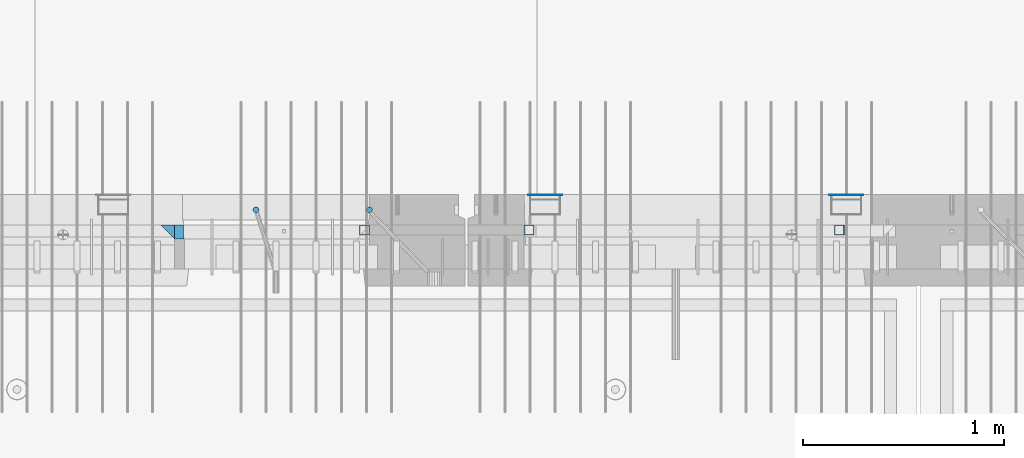
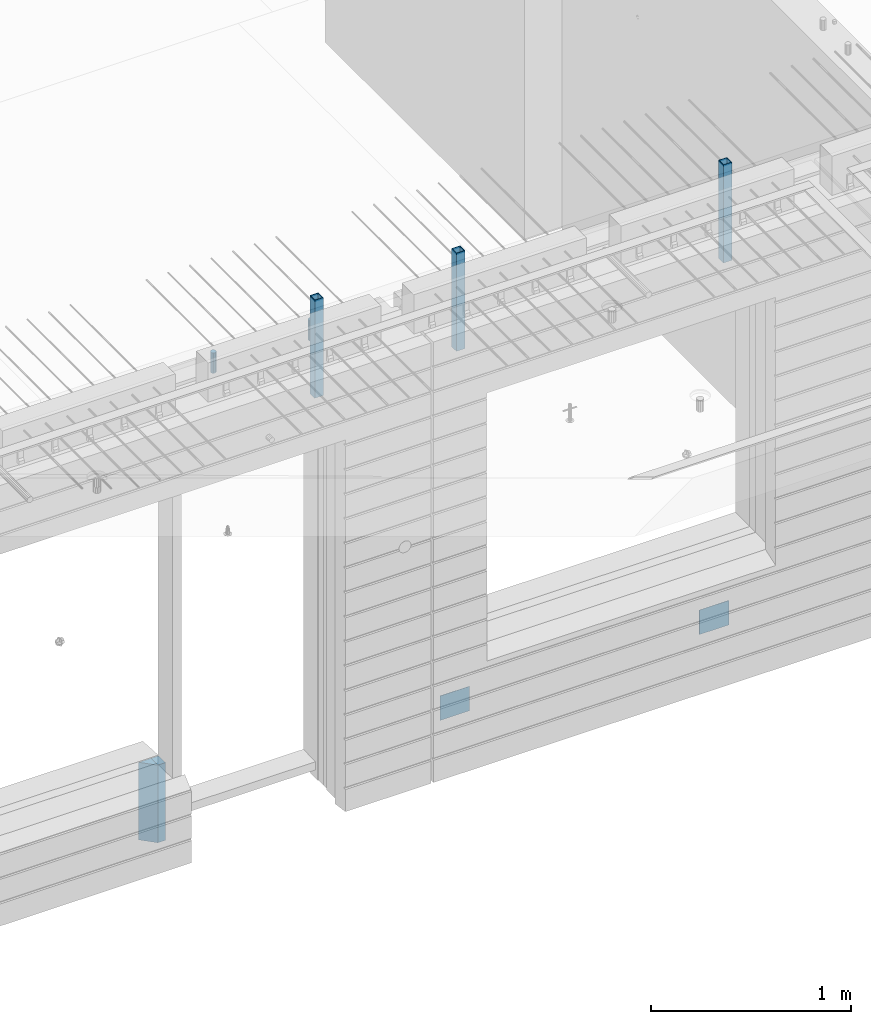
# One storey, part 17 of 352: 9 columns, 7 elements without a shape of their own.
"""IFC2X3 building model written with IfcOpenShell, lengths in millimetres."""

from ifc_helpers import new_model, si_unit, frame, origin_with_axes, place, context, subcontext, project, spatial, faceted_brep, material, type_object, element, aggregate, save


model = new_model("IFC2X3")

# Units and contexts
model_context = context("Model", 3, precision=1e-05, world=origin_with_axes())
body_context = subcontext(model_context, "Body", "Model", "MODEL_VIEW")
ifc_project = project(units=[si_unit("LENGTHUNIT", "METRE", prefix="MILLI"), si_unit("AREAUNIT", "SQUARE_METRE"), si_unit("VOLUMEUNIT", "CUBIC_METRE"), si_unit("MASSUNIT", "GRAM", prefix="KILO"), si_unit("TIMEUNIT", "SECOND"), si_unit("PLANEANGLEUNIT", "RADIAN"), si_unit("SOLIDANGLEUNIT", "STERADIAN"), si_unit("THERMODYNAMICTEMPERATUREUNIT", "DEGREE_CELSIUS"), si_unit("LUMINOUSINTENSITYUNIT", "LUMEN")], contexts=[model_context])

# Site, building, storey
site_placement = place(None, origin_with_axes())
site = spatial("IfcSite", under=ifc_project, at=site_placement, CompositionType="ELEMENT")
building_placement = place(site_placement, origin_with_axes())
building = spatial("IfcBuilding", under=site, at=building_placement, CompositionType="ELEMENT")
storey_placement = place(building_placement, origin_with_axes())
storey = spatial("IfcBuildingStorey", under=building, at=storey_placement, Name="6", CompositionType="ELEMENT", Elevation=0.0)

# Assembly, columns
assembly_1_placement = place(storey_placement, origin_with_axes())
assembly_1 = element("IfcElementAssembly", 1, at=assembly_1_placement, inside=storey, AssemblyPlace="NOTDEFINED", PredefinedType="REINFORCEMENT_UNIT")
ifc_material_1 = material(Name="CONCRETE/C35/45")
column_type_1 = type_object("IfcColumnType", PredefinedType="NOTDEFINED")
column_1_placement = place(assembly_1_placement, frame((24069.9998642727, 7815.0, 96755.0), z_axis=(1.0, 0.0, 0.0), x_axis=(0.0, 0.0, 1.0)))
column_1 = element("IfcColumn", 2, at=column_1_placement, type_object=column_type_1, material=ifc_material_1, Name="SK", context=body_context, shape_type="Brep", body=[
    faceted_brep([(0.0, -35.0, 35.0), (0.0, 35.0, 35.0), (0.0, -35.0, -35.0), (475.0, -35.0, 35.0), (475.0, -35.0, -35.0), (475.0, 35.0, 35.0)], [[[0, 1, 2]], [[3, 0, 2, 4]], [[3, 4, 5]], [[2, 1, 5, 4]], [[0, 3, 5, 1]]]),
])
column_type_2 = type_object("IfcColumnType", PredefinedType="NOTDEFINED")
column_2_placement = place(assembly_1_placement, frame((24129.9998642727, 7815.0, 96755.0), z_axis=(1.0, 0.0, 0.0), x_axis=(0.0, 0.0, 1.0)))
column_2 = element("IfcColumn", 3, at=column_2_placement, type_object=column_type_2, material=ifc_material_1, Name="SK", context=body_context, shape_type="Brep", body=[
    faceted_brep([(0.0, -35.0, -25.0), (0.0, 35.0, -25.0), (475.0, 35.0, -25.0), (475.0, -35.0, -25.0), (0.0, -35.0, 18.8457723764259), (0.0, 35.0, 20.640644171297), (475.0, 35.0, 20.640644171297), (475.0, -35.0, 18.8457723764259)], [[[0, 1, 2, 3]], [[1, 0, 4, 5]], [[2, 1, 5, 6]], [[3, 2, 6, 7]], [[0, 3, 7, 4]], [[6, 5, 4, 7]]]),
])
ifc_material_2 = material()
column_type_3 = type_object("IfcColumnType", Name="D30", PredefinedType="NOTDEFINED")
column_3_placement = place(assembly_1_placement, frame((24510.0000000048, 7924.99999999072, 99407.5), z_axis=(0.0, 1.0, 0.0), x_axis=(0.0, 0.0, 1.0)))
column_3 = element("IfcColumn", 4, at=column_3_placement, type_object=column_type_3, material=ifc_material_2, ObjectType="D30", context=body_context, shape_type="Brep", body=[
    faceted_brep([(0.0, -15.0, 0.0), (0.0, -12.9903810567666, -7.5), (125.0, -12.9903810567666, -7.5), (125.0, -15.0, 0.0), (0.0, -7.5, -12.9903810567666), (125.0, -7.5, -12.9903810567666), (0.0, 0.0, -15.0), (125.0, 0.0, -15.0), (0.0, 7.5, -12.9903810567666), (125.0, 7.5, -12.9903810567666), (0.0, 12.9903810567666, -7.5), (125.0, 12.9903810567666, -7.5), (0.0, 15.0, 0.0), (125.0, 15.0, 0.0), (0.0, 12.9903810567666, 7.5), (125.0, 12.9903810567666, 7.5), (0.0, 7.5, 12.9903810567666), (125.0, 7.5, 12.9903810567666), (0.0, 0.0, 15.0), (125.0, 0.0, 15.0), (0.0, -7.5, 12.9903810567666), (125.0, -7.5, 12.9903810567666), (0.0, -12.9903810567666, 7.5), (125.0, -12.9903810567666, 7.5)], [[[0, 1, 2, 3]], [[1, 4, 5, 2]], [[4, 6, 7, 5]], [[6, 8, 9, 7]], [[8, 10, 11, 9]], [[10, 12, 13, 11]], [[12, 14, 15, 13]], [[14, 16, 17, 15]], [[16, 18, 19, 17]], [[18, 20, 21, 19]], [[20, 22, 23, 21]], [[22, 0, 3, 23]], [[5, 7, 9, 11, 13, 15, 17, 19, 21, 23, 3, 2]], [[22, 20, 18, 16, 14, 12, 10, 8, 6, 4, 1, 0]]]),
])
column_4_placement = place(assembly_1_placement, frame((25074.9926665377, 7925.00000000707, 99407.5), z_axis=(0.0, 1.0, 0.0), x_axis=(0.0, 0.0, 1.0)))
column_4 = element("IfcColumn", 5, at=column_4_placement, type_object=column_type_3, material=ifc_material_2, ObjectType="D30", context=body_context, shape_type="Brep", body=[
    faceted_brep([(0.0, -15.0, 0.0), (0.0, -12.9903810567666, -7.5), (125.0, -12.9903810567666, -7.5), (125.0, -15.0, 0.0), (0.0, -7.5, -12.9903810567666), (125.0, -7.5, -12.9903810567666), (0.0, 0.0, -15.0), (125.0, 0.0, -15.0), (0.0, 7.5, -12.9903810567666), (125.0, 7.5, -12.9903810567666), (0.0, 12.9903810567666, -7.5), (125.0, 12.9903810567666, -7.5), (0.0, 15.0, 0.0), (125.0, 15.0, 0.0), (0.0, 12.9903810567666, 7.5), (125.0, 12.9903810567666, 7.5), (0.0, 7.5, 12.9903810567666), (125.0, 7.5, 12.9903810567666), (0.0, 0.0, 15.0), (125.0, 0.0, 15.0), (0.0, -7.5, 12.9903810567666), (125.0, -7.5, 12.9903810567666), (0.0, -12.9903810567666, 7.5), (125.0, -12.9903810567666, 7.5)], [[[0, 1, 2, 3]], [[1, 4, 5, 2]], [[4, 6, 7, 5]], [[6, 8, 9, 7]], [[8, 10, 11, 9]], [[10, 12, 13, 11]], [[12, 14, 15, 13]], [[14, 16, 17, 15]], [[16, 18, 19, 17]], [[18, 20, 21, 19]], [[20, 22, 23, 21]], [[22, 0, 3, 23]], [[5, 7, 9, 11, 13, 15, 17, 19, 21, 23, 3, 2]], [[22, 20, 18, 16, 14, 12, 10, 8, 6, 4, 1, 0]]]),
])

# Assemblies, columns
assembly_2_placement = place(storey_placement, origin_with_axes())
assembly_2 = element("IfcElementAssembly", 6, at=assembly_2_placement, inside=storey, AssemblyPlace="NOTDEFINED", PredefinedType="REINFORCEMENT_UNIT")
assembly_3_placement = place(assembly_2_placement, origin_with_axes())
assembly_3 = element("IfcElementAssembly", 7, at=assembly_3_placement, Name="Steel Assembly", AssemblyPlace="NOTDEFINED", PredefinedType="NOTDEFINED")
ifc_material_3 = material(Name="Undefined")
column_type_4 = type_object("IfcColumnType", PredefinedType="NOTDEFINED")
column_5_placement = place(assembly_3_placement, frame((25950.0, 7998.99999999844, 96754.9999999985), z_axis=(0.0, 1.0, 0.0), x_axis=(0.0, 0.0, 1.0)))
column_5 = element("IfcColumn", 8, at=column_5_placement, type_object=column_type_4, material=ifc_material_3, Name="SPK2", context=body_context, shape_type="Brep", body=[
    faceted_brep([(0.0, 85.0, -1.0), (0.0, 85.0, 1.0), (150.0, 85.0, 1.0), (150.0, 85.0, -1.0), (0.0, -85.0, 1.0), (150.0, -85.0, 1.0), (0.0, -85.0, -1.0), (150.0, -85.0, -1.0)], [[[0, 1, 2, 3]], [[1, 4, 5, 2]], [[4, 6, 7, 5]], [[6, 0, 3, 7]], [[5, 7, 3, 2]], [[6, 4, 1, 0]]]),
])
aggregate(assembly_3, [column_5])
assembly_4_placement = place(assembly_2_placement, origin_with_axes())
assembly_4 = element("IfcElementAssembly", 9, at=assembly_4_placement, Name="Steel Assembly", AssemblyPlace="NOTDEFINED", PredefinedType="NOTDEFINED")
column_6_placement = place(assembly_4_placement, frame((27450.0, 7998.99999999844, 96754.9999999985), z_axis=(0.0, 1.0, 0.0), x_axis=(0.0, 0.0, 1.0)))
column_6 = element("IfcColumn", 10, at=column_6_placement, type_object=column_type_4, material=ifc_material_3, Name="SPK2", context=body_context, shape_type="Brep", body=[
    faceted_brep([(0.0, 85.0, -1.0), (0.0, 85.0, 1.0), (150.0, 85.0, 1.0), (150.0, 85.0, -1.0), (0.0, -85.0, 1.0), (150.0, -85.0, 1.0), (0.0, -85.0, -1.0), (150.0, -85.0, -1.0)], [[[0, 1, 2, 3]], [[1, 4, 5, 2]], [[4, 6, 7, 5]], [[6, 0, 3, 7]], [[5, 7, 3, 2]], [[6, 4, 1, 0]]]),
])
aggregate(assembly_4, [column_6])

# Assembly
assembly_5_placement = place(assembly_1_placement, origin_with_axes())
assembly_5 = element("IfcElementAssembly", 11, at=assembly_5_placement, Name="Steel Assembly", AssemblyPlace="NOTDEFINED", PredefinedType="RIGID_FRAME")

aggregate(assembly_1, [column_3, column_4, assembly_5, column_1, column_2])

# Column
ifc_material_4 = material(Name="STEEL/S355J2")
column_type_5 = type_object("IfcColumnType", Name="50X50X3", PredefinedType="NOTDEFINED")
column_7_placement = place(assembly_5_placement, frame((25050.0, 7825.0, 99140.0), z_axis=(-1.0, 3.00000001838171e-08, 0.0), x_axis=(0.0, 0.0, 1.0)))
column_7 = element("IfcColumn", 12, at=column_7_placement, type_object=column_type_5, material=ifc_material_4, ObjectType="50X50X3", context=body_context, shape_type="Brep", body=[
    faceted_brep([(0.0, 22.0, -22.0), (0.0, -22.0, -22.0), (600.0, -22.0, -22.0), (600.0, 22.0, -22.0), (0.0, -22.0, 22.0), (600.0, -22.0, 22.0), (0.0, 22.0, 22.0), (600.0, 22.0, 22.0), (0.0, 25.0, -25.0), (0.0, 25.0, 25.0), (600.0, 25.0, 25.0), (600.0, 25.0, -25.0), (0.0, -25.0, 25.0), (600.0, -25.0, 25.0), (0.0, -25.0, -25.0), (600.0, -25.0, -25.0)], [[[0, 1, 2, 3]], [[1, 4, 5, 2]], [[4, 6, 7, 5]], [[6, 0, 3, 7]], [[8, 9, 10, 11]], [[9, 12, 13, 10]], [[12, 14, 15, 13]], [[14, 8, 11, 15]], [[13, 15, 11, 10], [5, 7, 3, 2]], [[14, 12, 9, 8], [6, 4, 1, 0]]]),
])

aggregate(assembly_5, [column_7])

# Assembly, column
assembly_6_placement = place(assembly_2_placement, origin_with_axes())
assembly_6 = element("IfcElementAssembly", 13, at=assembly_6_placement, Name="Steel Assembly", AssemblyPlace="NOTDEFINED", PredefinedType="RIGID_FRAME")
column_8_placement = place(assembly_6_placement, frame((25870.0, 7825.0, 99140.0), z_axis=(-1.0, 3.00000001838171e-08, 0.0), x_axis=(0.0, 0.0, 1.0)))
column_8 = element("IfcColumn", 14, at=column_8_placement, type_object=column_type_5, material=ifc_material_4, ObjectType="50X50X3", context=body_context, shape_type="Brep", body=[
    faceted_brep([(0.0, 22.0, -22.0), (0.0, -22.0, -22.0), (600.0, -22.0, -22.0), (600.0, 22.0, -22.0), (0.0, -22.0, 22.0), (600.0, -22.0, 22.0), (0.0, 22.0, 22.0), (600.0, 22.0, 22.0), (0.0, 25.0, -25.0), (0.0, 25.0, 25.0), (600.0, 25.0, 25.0), (600.0, 25.0, -25.0), (0.0, -25.0, 25.0), (600.0, -25.0, 25.0), (0.0, -25.0, -25.0), (600.0, -25.0, -25.0)], [[[0, 1, 2, 3]], [[1, 4, 5, 2]], [[4, 6, 7, 5]], [[6, 0, 3, 7]], [[8, 9, 10, 11]], [[9, 12, 13, 10]], [[12, 14, 15, 13]], [[14, 8, 11, 15]], [[13, 15, 11, 10], [5, 7, 3, 2]], [[14, 12, 9, 8], [6, 4, 1, 0]]]),
])
aggregate(assembly_6, [column_8])

# Assembly
assembly_7_placement = place(assembly_2_placement, origin_with_axes())
assembly_7 = element("IfcElementAssembly", 15, at=assembly_7_placement, Name="Steel Assembly", AssemblyPlace="NOTDEFINED", PredefinedType="RIGID_FRAME")

aggregate(assembly_2, [assembly_3, assembly_4, assembly_6, assembly_7])

# Column
column_9_placement = place(assembly_7_placement, frame((27415.0, 7825.0, 99140.0), z_axis=(-1.0, 3.00000001838171e-08, 0.0), x_axis=(0.0, 0.0, 1.0)))
column_9 = element("IfcColumn", 16, at=column_9_placement, type_object=column_type_5, material=ifc_material_4, ObjectType="50X50X3", context=body_context, shape_type="Brep", body=[
    faceted_brep([(0.0, 22.0, -22.0), (0.0, -22.0, -22.0), (600.0, -22.0, -22.0), (600.0, 22.0, -22.0), (0.0, -22.0, 22.0), (600.0, -22.0, 22.0), (0.0, 22.0, 22.0), (600.0, 22.0, 22.0), (0.0, 25.0, -25.0), (0.0, 25.0, 25.0), (600.0, 25.0, 25.0), (600.0, 25.0, -25.0), (0.0, -25.0, 25.0), (600.0, -25.0, 25.0), (0.0, -25.0, -25.0), (600.0, -25.0, -25.0)], [[[0, 1, 2, 3]], [[1, 4, 5, 2]], [[4, 6, 7, 5]], [[6, 0, 3, 7]], [[8, 9, 10, 11]], [[9, 12, 13, 10]], [[12, 14, 15, 13]], [[14, 8, 11, 15]], [[13, 15, 11, 10], [5, 7, 3, 2]], [[14, 12, 9, 8], [6, 4, 1, 0]]]),
])

aggregate(assembly_7, [column_9])

save(model, "model.ifc")
